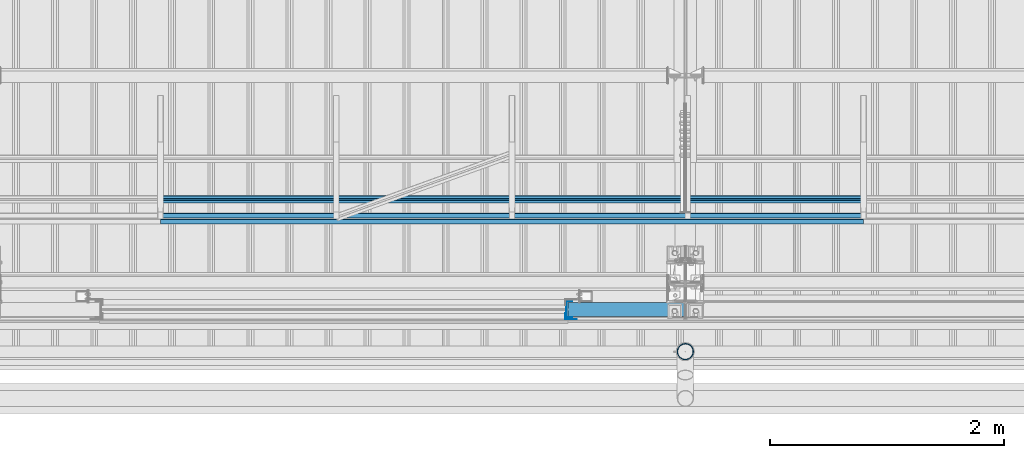
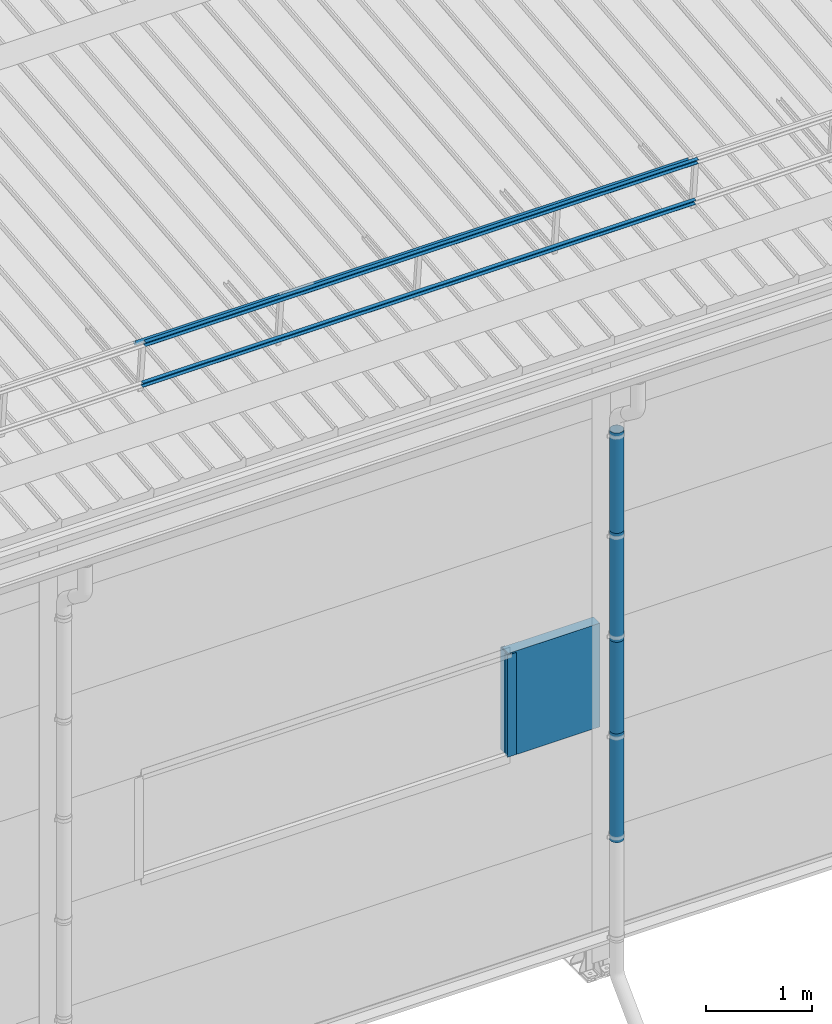
# One storey, part 63 of 709: 10 beams, 10 elements without a shape of their own.
"""IFC4 building model written with IfcOpenShell, lengths in millimetres."""

from ifc_helpers import new_model, si_unit, direction, frame, origin_with_axes, place, context, subcontext, project, spatial, line, indexed_curve, outline, extrude, material, element, aggregate, save


model = new_model("IFC4")

# Units and contexts
model_context = context("Model", 3, precision=0.2, world=origin_with_axes(), true_north=direction((0.0, 1.0)))
body_context = subcontext(model_context, "Body", "Model", "MODEL_VIEW")
ifc_project = project(units=[si_unit("LENGTHUNIT", "METRE", prefix="MILLI"), si_unit("AREAUNIT", "SQUARE_METRE"), si_unit("VOLUMEUNIT", "CUBIC_METRE"), si_unit("MASSUNIT", "GRAM", prefix="KILO"), si_unit("TIMEUNIT", "SECOND"), si_unit("PLANEANGLEUNIT", "RADIAN"), si_unit("SOLIDANGLEUNIT", "STERADIAN"), si_unit("THERMODYNAMICTEMPERATUREUNIT", "DEGREE_CELSIUS"), si_unit("LUMINOUSINTENSITYUNIT", "LUMEN")], contexts=[model_context])

# Site, building, storey
site_placement = place(None, origin_with_axes())
site = spatial("IfcSite", under=ifc_project, at=site_placement, CompositionType="ELEMENT")
building_placement = place(site_placement, origin_with_axes())
building = spatial("IfcBuilding", under=site, at=building_placement, Name="Undefined", CompositionType="ELEMENT")
storey_placement = place(building_placement, origin_with_axes())
storey = spatial("IfcBuildingStorey", under=building, at=storey_placement, Name="Undefined", CompositionType="ELEMENT", Elevation=0.0)

# Assembly, beam
assembly_1_placement = place(storey_placement, frame((29520.0, 691.31008, 8152.29341), z_axis=(0.0, -0.9950371902, -0.099503719), x_axis=(1.0, 0.0, 0.0)))
assembly_1 = element("IfcElementAssembly", 1, at=assembly_1_placement, inside=storey)
ifc_material_1 = material(Name="Steel_Undefined", Category="STEEL")
beam_1_placement = place(assembly_1_placement, origin_with_axes())
beam_1 = element("IfcBeam", 2, at=beam_1_placement, material=ifc_material_1, ObjectType="606", context=body_context, shape_type="SolidModel", body=[
    extrude(outline(indexed_curve([(-20.0, -25.0), (20.0, -25.0), (20.0, -22.5), (-17.5, -22.5), (-17.5, 22.5), (20.0, 22.5), (20.0, 25.0), (-20.0, 25.0)], segments=[line(1, 2, 3, 4, 5, 6, 7, 8, 1)])), frame((0.0, 0.0, 0.0), z_axis=(-1.0, 0.0, 0.0), x_axis=(0.0, 0.0, 1.0)), (0.0, 0.0, -1.0), 6000.0),
])
aggregate(assembly_1, [beam_1])

assembly_2_placement = place(storey_placement, frame((29520.0, 741.06194, 7654.77481), z_axis=(0.0, -0.9950371902, -0.099503719), x_axis=(1.0, 0.0, 0.0)))
assembly_2 = element("IfcElementAssembly", 3, at=assembly_2_placement, inside=storey)
beam_2_placement = place(assembly_2_placement, origin_with_axes())
beam_2 = element("IfcBeam", 4, at=beam_2_placement, material=ifc_material_1, ObjectType="606", context=body_context, shape_type="SolidModel", body=[
    extrude(outline(indexed_curve([(-20.0, -25.0), (20.0, -25.0), (20.0, -22.5), (-17.5, -22.5), (-17.5, 22.5), (20.0, 22.5), (20.0, 25.0), (-20.0, 25.0)], segments=[line(1, 2, 3, 4, 5, 6, 7, 8, 1)])), frame((0.0, 0.0, 0.0), z_axis=(-1.0, 0.0, 0.0), x_axis=(0.0, 0.0, 1.0)), (0.0, 0.0, -1.0), 6000.0),
])
aggregate(assembly_2, [beam_2])

assembly_3_placement = place(storey_placement, frame((29520.0, 878.66704, 8043.11507), z_axis=(0.0, 0.6332377902, 0.7739572992), x_axis=(1.0, 0.0, 0.0)))
assembly_3 = element("IfcElementAssembly", 5, at=assembly_3_placement, inside=storey)
beam_3_placement = place(assembly_3_placement, origin_with_axes())
beam_3 = element("IfcBeam", 6, at=beam_3_placement, material=ifc_material_1, ObjectType="606", context=body_context, shape_type="SolidModel", body=[
    extrude(outline(indexed_curve([(-20.0, -25.0), (20.0, -25.0), (20.0, -22.5), (-17.5, -22.5), (-17.5, 22.5), (20.0, 22.5), (20.0, 25.0), (-20.0, 25.0)], segments=[line(1, 2, 3, 4, 5, 6, 7, 8, 1)])), frame((0.0, 0.0, 0.0), z_axis=(-1.0, 0.0, 0.0), x_axis=(0.0, 0.0, 1.0)), (0.0, 0.0, -1.0), 6000.0),
])
aggregate(assembly_3, [beam_3])

assembly_4_placement = place(storey_placement, frame((33000.0, -60.0, 3275.0), z_axis=(0.0, 0.0, -1.0), x_axis=(1.0, 0.0, 0.0)))
assembly_4 = element("IfcElementAssembly", 7, at=assembly_4_placement, inside=storey)
ifc_material_2 = material(Name="Insulation", Category="Insulation")
beam_4_placement = place(assembly_4_placement, origin_with_axes())
beam_4 = element("IfcBeam", 8, at=beam_4_placement, material=ifc_material_2, ObjectType="P-110", context=body_context, shape_type="SolidModel", body=[
    extrude(outline(indexed_curve([(-595.0, -60.0), (595.0, -60.0), (595.0, 60.0), (-595.0, 60.0)], segments=[line(1, 2, 3, 4, 1)])), frame((0.0, 0.0, 0.0), z_axis=(-1.0, 0.0, 0.0), x_axis=(0.0, 0.0, 1.0)), (0.0, 0.0, -1.0), 990.0),
])
aggregate(assembly_4, [beam_4])

assembly_5_placement = place(storey_placement, frame((33010.0, -60.0, 3870.0), z_axis=(0.0, 1.0, 0.0), x_axis=(0.0, 0.0, -1.0)))
assembly_5 = element("IfcElementAssembly", 9, at=assembly_5_placement, inside=storey)
beam_5_placement = place(assembly_5_placement, origin_with_axes())
beam_5 = element("IfcBeam", 10, at=beam_5_placement, material=ifc_material_1, context=body_context, shape_type="SolidModel", body=[
    extrude(outline(indexed_curve([(-70.0, -25.0), (-68.0, -25.0), (-68.0, 23.0), (68.0, 23.0), (68.0, -25.0), (70.0, -25.0), (70.0, 25.0), (-70.0, 25.0)], segments=[line(1, 2, 3, 4, 5, 6, 7, 8, 1)])), frame((0.0, 0.0, 0.0), z_axis=(-1.0, 0.0, 0.0), x_axis=(0.0, 0.0, 1.0)), (0.0, 0.0, -1.0), 1170.0),
])
aggregate(assembly_5, [beam_5])

assembly_6_placement = place(storey_placement, frame((32975.0, -119.0, 3870.0), z_axis=(0.0, -1.0, 0.0), x_axis=(0.0, 0.0, -1.0)))
assembly_6 = element("IfcElementAssembly", 11, at=assembly_6_placement, inside=storey)
beam_6_placement = place(assembly_6_placement, origin_with_axes())
beam_6 = element("IfcBeam", 12, at=beam_6_placement, material=ifc_material_1, context=body_context, shape_type="SolidModel", body=[
    extrude(outline(indexed_curve([(-25.0, -1.0), (25.0, -1.0), (25.0, 99.0), (23.0, 99.0), (23.0, 1.0), (-25.0, 1.0)], segments=[line(1, 2, 3, 4, 5, 6, 1)])), frame((0.0, 0.0, 0.0), z_axis=(-1.0, 0.0, 0.0), x_axis=(0.0, 0.0, 1.0)), (0.0, 0.0, -1.0), 1170.0),
])
aggregate(assembly_6, [beam_6])

assembly_7_placement = place(storey_placement, frame((34000.0, -420.0, 6276.92297), z_axis=(0.0, 1.0, 0.0), x_axis=(0.0, 0.0, -1.0)))
assembly_7 = element("IfcElementAssembly", 13, at=assembly_7_placement, inside=storey)
beam_7_placement = place(assembly_7_placement, origin_with_axes())
beam_7 = element("IfcBeam", 14, at=beam_7_placement, material=ifc_material_1, ObjectType="614", context=body_context, shape_type="SolidModel", body=[
    extrude(outline(indexed_curve([(70.0, 0.0), (69.61653, 7.31699), (68.47033, 14.55382), (66.57396, 21.63119), (63.94818, 28.47157), (60.62178, 35.0), (56.63119, 41.14497), (52.02014, 46.83914), (46.83914, 52.02014), (41.14497, 56.63119), (35.0, 60.62178), (28.47157, 63.94818), (21.63119, 66.57396), (14.55382, 68.47033), (7.31699, 69.61653), (0.0, 70.0), (-7.31699, 69.61653), (-14.55382, 68.47033), (-21.63119, 66.57396), (-28.47157, 63.94818), (-35.0, 60.62178), (-41.14497, 56.63119), (-46.83914, 52.02014), (-52.02014, 46.83914), (-56.63119, 41.14497), (-60.62178, 35.0), (-63.94818, 28.47157), (-66.57396, 21.63119), (-68.47033, 14.55382), (-69.61653, 7.31699), (-70.0, 0.0), (-69.61653, -7.31699), (-68.47033, -14.55382), (-66.57396, -21.63119), (-63.94818, -28.47157), (-60.62178, -35.0), (-56.63119, -41.14497), (-52.02014, -46.83914), (-46.83914, -52.02014), (-41.14497, -56.63119), (-35.0, -60.62178), (-28.47157, -63.94818), (-21.63119, -66.57396), (-14.55382, -68.47033), (-7.31699, -69.61653), (0.0, -70.0), (7.31699, -69.61653), (14.55382, -68.47033), (21.63119, -66.57396), (28.47157, -63.94818), (35.0, -60.62178), (41.14497, -56.63119), (46.83914, -52.02014), (52.02014, -46.83914), (56.63119, -41.14497), (60.62178, -35.0), (63.94818, -28.47157), (66.57396, -21.63119), (68.47033, -14.55382), (69.61653, -7.31699)], segments=[line(1, 2, 3, 4, 5, 6, 7, 8, 9, 10, 11, 12, 13, 14, 15, 16, 17, 18, 19, 20, 21, 22, 23, 24, 25, 26, 27, 28, 29, 30, 31, 32, 33, 34, 35, 36, 37, 38, 39, 40, 41, 42, 43, 44, 45, 46, 47, 48, 49, 50, 51, 52, 53, 54, 55, 56, 57, 58, 59, 60, 1)]), holes=[indexed_curve([(65.0, 0.0), (64.64392, -6.79435), (63.57959, -13.51426), (61.81867, -20.0861), (59.38045, -26.43788), (56.29165, -32.5), (52.5861, -38.20604), (48.30441, -43.49349), (43.49349, -48.30441), (38.20604, -52.5861), (32.5, -56.29165), (26.43788, -59.38045), (20.0861, -61.81867), (13.51426, -63.57959), (6.79435, -64.64392), (0.0, -65.0), (-6.79435, -64.64392), (-13.51426, -63.57959), (-20.0861, -61.81867), (-26.43788, -59.38045), (-32.5, -56.29165), (-38.20604, -52.5861), (-43.49349, -48.30441), (-48.30441, -43.49349), (-52.5861, -38.20604), (-56.29165, -32.5), (-59.38045, -26.43788), (-61.81867, -20.0861), (-63.57959, -13.51426), (-64.64392, -6.79435), (-65.0, 0.0), (-64.64392, 6.79435), (-63.57959, 13.51426), (-61.81867, 20.0861), (-59.38045, 26.43788), (-56.29165, 32.5), (-52.5861, 38.20604), (-48.30441, 43.49349), (-43.49349, 48.30441), (-38.20604, 52.5861), (-32.5, 56.29165), (-26.43788, 59.38045), (-20.0861, 61.81867), (-13.51426, 63.57959), (-6.79435, 64.64392), (0.0, 65.0), (6.79435, 64.64392), (13.51426, 63.57959), (20.0861, 61.81867), (26.43788, 59.38045), (32.5, 56.29165), (38.20604, 52.5861), (43.49349, 48.30441), (48.30441, 43.49349), (52.5861, 38.20604), (56.29165, 32.5), (59.38045, 26.43788), (61.81867, 20.0861), (63.57959, 13.51426), (64.64392, 6.79435)], segments=[line(1, 2, 3, 4, 5, 6, 7, 8, 9, 10, 11, 12, 13, 14, 15, 16, 17, 18, 19, 20, 21, 22, 23, 24, 25, 26, 27, 28, 29, 30, 31, 32, 33, 34, 35, 36, 37, 38, 39, 40, 41, 42, 43, 44, 45, 46, 47, 48, 49, 50, 51, 52, 53, 54, 55, 56, 57, 58, 59, 60, 1)])]), frame((0.0, 0.0, 0.0), z_axis=(-1.0, 0.0, 0.0), x_axis=(0.0, 0.0, 1.0)), (0.0, 0.0, -1.0), 1250.0),
])
aggregate(assembly_7, [beam_7])

assembly_8_placement = place(storey_placement, frame((34000.0, -420.0, 5126.92297), z_axis=(0.0, 1.0, 0.0), x_axis=(0.0, 0.0, -1.0)))
assembly_8 = element("IfcElementAssembly", 15, at=assembly_8_placement, inside=storey)
beam_8_placement = place(assembly_8_placement, origin_with_axes())
beam_8 = element("IfcBeam", 16, at=beam_8_placement, material=ifc_material_1, ObjectType="614", context=body_context, shape_type="SolidModel", body=[
    extrude(outline(indexed_curve([(70.0, 0.0), (69.61653, 7.31699), (68.47033, 14.55382), (66.57396, 21.63119), (63.94818, 28.47157), (60.62178, 35.0), (56.63119, 41.14497), (52.02014, 46.83914), (46.83914, 52.02014), (41.14497, 56.63119), (35.0, 60.62178), (28.47157, 63.94818), (21.63119, 66.57396), (14.55382, 68.47033), (7.31699, 69.61653), (0.0, 70.0), (-7.31699, 69.61653), (-14.55382, 68.47033), (-21.63119, 66.57396), (-28.47157, 63.94818), (-35.0, 60.62178), (-41.14497, 56.63119), (-46.83914, 52.02014), (-52.02014, 46.83914), (-56.63119, 41.14497), (-60.62178, 35.0), (-63.94818, 28.47157), (-66.57396, 21.63119), (-68.47033, 14.55382), (-69.61653, 7.31699), (-70.0, 0.0), (-69.61653, -7.31699), (-68.47033, -14.55382), (-66.57396, -21.63119), (-63.94818, -28.47157), (-60.62178, -35.0), (-56.63119, -41.14497), (-52.02014, -46.83914), (-46.83914, -52.02014), (-41.14497, -56.63119), (-35.0, -60.62178), (-28.47157, -63.94818), (-21.63119, -66.57396), (-14.55382, -68.47033), (-7.31699, -69.61653), (0.0, -70.0), (7.31699, -69.61653), (14.55382, -68.47033), (21.63119, -66.57396), (28.47157, -63.94818), (35.0, -60.62178), (41.14497, -56.63119), (46.83914, -52.02014), (52.02014, -46.83914), (56.63119, -41.14497), (60.62178, -35.0), (63.94818, -28.47157), (66.57396, -21.63119), (68.47033, -14.55382), (69.61653, -7.31699)], segments=[line(1, 2, 3, 4, 5, 6, 7, 8, 9, 10, 11, 12, 13, 14, 15, 16, 17, 18, 19, 20, 21, 22, 23, 24, 25, 26, 27, 28, 29, 30, 31, 32, 33, 34, 35, 36, 37, 38, 39, 40, 41, 42, 43, 44, 45, 46, 47, 48, 49, 50, 51, 52, 53, 54, 55, 56, 57, 58, 59, 60, 1)]), holes=[indexed_curve([(65.0, 0.0), (64.64392, -6.79435), (63.57959, -13.51426), (61.81867, -20.0861), (59.38045, -26.43788), (56.29165, -32.5), (52.5861, -38.20604), (48.30441, -43.49349), (43.49349, -48.30441), (38.20604, -52.5861), (32.5, -56.29165), (26.43788, -59.38045), (20.0861, -61.81867), (13.51426, -63.57959), (6.79435, -64.64392), (0.0, -65.0), (-6.79435, -64.64392), (-13.51426, -63.57959), (-20.0861, -61.81867), (-26.43788, -59.38045), (-32.5, -56.29165), (-38.20604, -52.5861), (-43.49349, -48.30441), (-48.30441, -43.49349), (-52.5861, -38.20604), (-56.29165, -32.5), (-59.38045, -26.43788), (-61.81867, -20.0861), (-63.57959, -13.51426), (-64.64392, -6.79435), (-65.0, 0.0), (-64.64392, 6.79435), (-63.57959, 13.51426), (-61.81867, 20.0861), (-59.38045, 26.43788), (-56.29165, 32.5), (-52.5861, 38.20604), (-48.30441, 43.49349), (-43.49349, 48.30441), (-38.20604, 52.5861), (-32.5, 56.29165), (-26.43788, 59.38045), (-20.0861, 61.81867), (-13.51426, 63.57959), (-6.79435, 64.64392), (0.0, 65.0), (6.79435, 64.64392), (13.51426, 63.57959), (20.0861, 61.81867), (26.43788, 59.38045), (32.5, 56.29165), (38.20604, 52.5861), (43.49349, 48.30441), (48.30441, 43.49349), (52.5861, 38.20604), (56.29165, 32.5), (59.38045, 26.43788), (61.81867, 20.0861), (63.57959, 13.51426), (64.64392, 6.79435)], segments=[line(1, 2, 3, 4, 5, 6, 7, 8, 9, 10, 11, 12, 13, 14, 15, 16, 17, 18, 19, 20, 21, 22, 23, 24, 25, 26, 27, 28, 29, 30, 31, 32, 33, 34, 35, 36, 37, 38, 39, 40, 41, 42, 43, 44, 45, 46, 47, 48, 49, 50, 51, 52, 53, 54, 55, 56, 57, 58, 59, 60, 1)])]), frame((0.0, 0.0, 0.0), z_axis=(-1.0, 0.0, 0.0), x_axis=(0.0, 0.0, 1.0)), (0.0, 0.0, -1.0), 1250.0),
])
aggregate(assembly_8, [beam_8])

assembly_9_placement = place(storey_placement, frame((34000.0, -420.0, 3976.92297), z_axis=(0.0, 1.0, 0.0), x_axis=(0.0, 0.0, -1.0)))
assembly_9 = element("IfcElementAssembly", 17, at=assembly_9_placement, inside=storey)
beam_9_placement = place(assembly_9_placement, origin_with_axes())
beam_9 = element("IfcBeam", 18, at=beam_9_placement, material=ifc_material_1, ObjectType="614", context=body_context, shape_type="SolidModel", body=[
    extrude(outline(indexed_curve([(70.0, 0.0), (69.61653, 7.31699), (68.47033, 14.55382), (66.57396, 21.63119), (63.94818, 28.47157), (60.62178, 35.0), (56.63119, 41.14497), (52.02014, 46.83914), (46.83914, 52.02014), (41.14497, 56.63119), (35.0, 60.62178), (28.47157, 63.94818), (21.63119, 66.57396), (14.55382, 68.47033), (7.31699, 69.61653), (0.0, 70.0), (-7.31699, 69.61653), (-14.55382, 68.47033), (-21.63119, 66.57396), (-28.47157, 63.94818), (-35.0, 60.62178), (-41.14497, 56.63119), (-46.83914, 52.02014), (-52.02014, 46.83914), (-56.63119, 41.14497), (-60.62178, 35.0), (-63.94818, 28.47157), (-66.57396, 21.63119), (-68.47033, 14.55382), (-69.61653, 7.31699), (-70.0, 0.0), (-69.61653, -7.31699), (-68.47033, -14.55382), (-66.57396, -21.63119), (-63.94818, -28.47157), (-60.62178, -35.0), (-56.63119, -41.14497), (-52.02014, -46.83914), (-46.83914, -52.02014), (-41.14497, -56.63119), (-35.0, -60.62178), (-28.47157, -63.94818), (-21.63119, -66.57396), (-14.55382, -68.47033), (-7.31699, -69.61653), (0.0, -70.0), (7.31699, -69.61653), (14.55382, -68.47033), (21.63119, -66.57396), (28.47157, -63.94818), (35.0, -60.62178), (41.14497, -56.63119), (46.83914, -52.02014), (52.02014, -46.83914), (56.63119, -41.14497), (60.62178, -35.0), (63.94818, -28.47157), (66.57396, -21.63119), (68.47033, -14.55382), (69.61653, -7.31699)], segments=[line(1, 2, 3, 4, 5, 6, 7, 8, 9, 10, 11, 12, 13, 14, 15, 16, 17, 18, 19, 20, 21, 22, 23, 24, 25, 26, 27, 28, 29, 30, 31, 32, 33, 34, 35, 36, 37, 38, 39, 40, 41, 42, 43, 44, 45, 46, 47, 48, 49, 50, 51, 52, 53, 54, 55, 56, 57, 58, 59, 60, 1)]), holes=[indexed_curve([(65.0, 0.0), (64.64392, -6.79435), (63.57959, -13.51426), (61.81867, -20.0861), (59.38045, -26.43788), (56.29165, -32.5), (52.5861, -38.20604), (48.30441, -43.49349), (43.49349, -48.30441), (38.20604, -52.5861), (32.5, -56.29165), (26.43788, -59.38045), (20.0861, -61.81867), (13.51426, -63.57959), (6.79435, -64.64392), (0.0, -65.0), (-6.79435, -64.64392), (-13.51426, -63.57959), (-20.0861, -61.81867), (-26.43788, -59.38045), (-32.5, -56.29165), (-38.20604, -52.5861), (-43.49349, -48.30441), (-48.30441, -43.49349), (-52.5861, -38.20604), (-56.29165, -32.5), (-59.38045, -26.43788), (-61.81867, -20.0861), (-63.57959, -13.51426), (-64.64392, -6.79435), (-65.0, 0.0), (-64.64392, 6.79435), (-63.57959, 13.51426), (-61.81867, 20.0861), (-59.38045, 26.43788), (-56.29165, 32.5), (-52.5861, 38.20604), (-48.30441, 43.49349), (-43.49349, 48.30441), (-38.20604, 52.5861), (-32.5, 56.29165), (-26.43788, 59.38045), (-20.0861, 61.81867), (-13.51426, 63.57959), (-6.79435, 64.64392), (0.0, 65.0), (6.79435, 64.64392), (13.51426, 63.57959), (20.0861, 61.81867), (26.43788, 59.38045), (32.5, 56.29165), (38.20604, 52.5861), (43.49349, 48.30441), (48.30441, 43.49349), (52.5861, 38.20604), (56.29165, 32.5), (59.38045, 26.43788), (61.81867, 20.0861), (63.57959, 13.51426), (64.64392, 6.79435)], segments=[line(1, 2, 3, 4, 5, 6, 7, 8, 9, 10, 11, 12, 13, 14, 15, 16, 17, 18, 19, 20, 21, 22, 23, 24, 25, 26, 27, 28, 29, 30, 31, 32, 33, 34, 35, 36, 37, 38, 39, 40, 41, 42, 43, 44, 45, 46, 47, 48, 49, 50, 51, 52, 53, 54, 55, 56, 57, 58, 59, 60, 1)])]), frame((0.0, 0.0, 0.0), z_axis=(-1.0, 0.0, 0.0), x_axis=(0.0, 0.0, 1.0)), (0.0, 0.0, -1.0), 1250.0),
])
aggregate(assembly_9, [beam_9])

assembly_10_placement = place(storey_placement, frame((34000.0, -420.0, 2826.92297), z_axis=(0.0, 1.0, 0.0), x_axis=(0.0, 0.0, -1.0)))
assembly_10 = element("IfcElementAssembly", 19, at=assembly_10_placement, inside=storey)
beam_10_placement = place(assembly_10_placement, origin_with_axes())
beam_10 = element("IfcBeam", 20, at=beam_10_placement, material=ifc_material_1, ObjectType="614", context=body_context, shape_type="SolidModel", body=[
    extrude(outline(indexed_curve([(70.0, 0.0), (69.61653, 7.31699), (68.47033, 14.55382), (66.57396, 21.63119), (63.94818, 28.47157), (60.62178, 35.0), (56.63119, 41.14497), (52.02014, 46.83914), (46.83914, 52.02014), (41.14497, 56.63119), (35.0, 60.62178), (28.47157, 63.94818), (21.63119, 66.57396), (14.55382, 68.47033), (7.31699, 69.61653), (0.0, 70.0), (-7.31699, 69.61653), (-14.55382, 68.47033), (-21.63119, 66.57396), (-28.47157, 63.94818), (-35.0, 60.62178), (-41.14497, 56.63119), (-46.83914, 52.02014), (-52.02014, 46.83914), (-56.63119, 41.14497), (-60.62178, 35.0), (-63.94818, 28.47157), (-66.57396, 21.63119), (-68.47033, 14.55382), (-69.61653, 7.31699), (-70.0, 0.0), (-69.61653, -7.31699), (-68.47033, -14.55382), (-66.57396, -21.63119), (-63.94818, -28.47157), (-60.62178, -35.0), (-56.63119, -41.14497), (-52.02014, -46.83914), (-46.83914, -52.02014), (-41.14497, -56.63119), (-35.0, -60.62178), (-28.47157, -63.94818), (-21.63119, -66.57396), (-14.55382, -68.47033), (-7.31699, -69.61653), (0.0, -70.0), (7.31699, -69.61653), (14.55382, -68.47033), (21.63119, -66.57396), (28.47157, -63.94818), (35.0, -60.62178), (41.14497, -56.63119), (46.83914, -52.02014), (52.02014, -46.83914), (56.63119, -41.14497), (60.62178, -35.0), (63.94818, -28.47157), (66.57396, -21.63119), (68.47033, -14.55382), (69.61653, -7.31699)], segments=[line(1, 2, 3, 4, 5, 6, 7, 8, 9, 10, 11, 12, 13, 14, 15, 16, 17, 18, 19, 20, 21, 22, 23, 24, 25, 26, 27, 28, 29, 30, 31, 32, 33, 34, 35, 36, 37, 38, 39, 40, 41, 42, 43, 44, 45, 46, 47, 48, 49, 50, 51, 52, 53, 54, 55, 56, 57, 58, 59, 60, 1)]), holes=[indexed_curve([(65.0, 0.0), (64.64392, -6.79435), (63.57959, -13.51426), (61.81867, -20.0861), (59.38045, -26.43788), (56.29165, -32.5), (52.5861, -38.20604), (48.30441, -43.49349), (43.49349, -48.30441), (38.20604, -52.5861), (32.5, -56.29165), (26.43788, -59.38045), (20.0861, -61.81867), (13.51426, -63.57959), (6.79435, -64.64392), (0.0, -65.0), (-6.79435, -64.64392), (-13.51426, -63.57959), (-20.0861, -61.81867), (-26.43788, -59.38045), (-32.5, -56.29165), (-38.20604, -52.5861), (-43.49349, -48.30441), (-48.30441, -43.49349), (-52.5861, -38.20604), (-56.29165, -32.5), (-59.38045, -26.43788), (-61.81867, -20.0861), (-63.57959, -13.51426), (-64.64392, -6.79435), (-65.0, 0.0), (-64.64392, 6.79435), (-63.57959, 13.51426), (-61.81867, 20.0861), (-59.38045, 26.43788), (-56.29165, 32.5), (-52.5861, 38.20604), (-48.30441, 43.49349), (-43.49349, 48.30441), (-38.20604, 52.5861), (-32.5, 56.29165), (-26.43788, 59.38045), (-20.0861, 61.81867), (-13.51426, 63.57959), (-6.79435, 64.64392), (0.0, 65.0), (6.79435, 64.64392), (13.51426, 63.57959), (20.0861, 61.81867), (26.43788, 59.38045), (32.5, 56.29165), (38.20604, 52.5861), (43.49349, 48.30441), (48.30441, 43.49349), (52.5861, 38.20604), (56.29165, 32.5), (59.38045, 26.43788), (61.81867, 20.0861), (63.57959, 13.51426), (64.64392, 6.79435)], segments=[line(1, 2, 3, 4, 5, 6, 7, 8, 9, 10, 11, 12, 13, 14, 15, 16, 17, 18, 19, 20, 21, 22, 23, 24, 25, 26, 27, 28, 29, 30, 31, 32, 33, 34, 35, 36, 37, 38, 39, 40, 41, 42, 43, 44, 45, 46, 47, 48, 49, 50, 51, 52, 53, 54, 55, 56, 57, 58, 59, 60, 1)])]), frame((0.0, 0.0, 0.0), z_axis=(-1.0, 0.0, 0.0), x_axis=(0.0, 0.0, 1.0)), (0.0, 0.0, -1.0), 1250.0),
])
aggregate(assembly_10, [beam_10])

save(model, "model.ifc")
